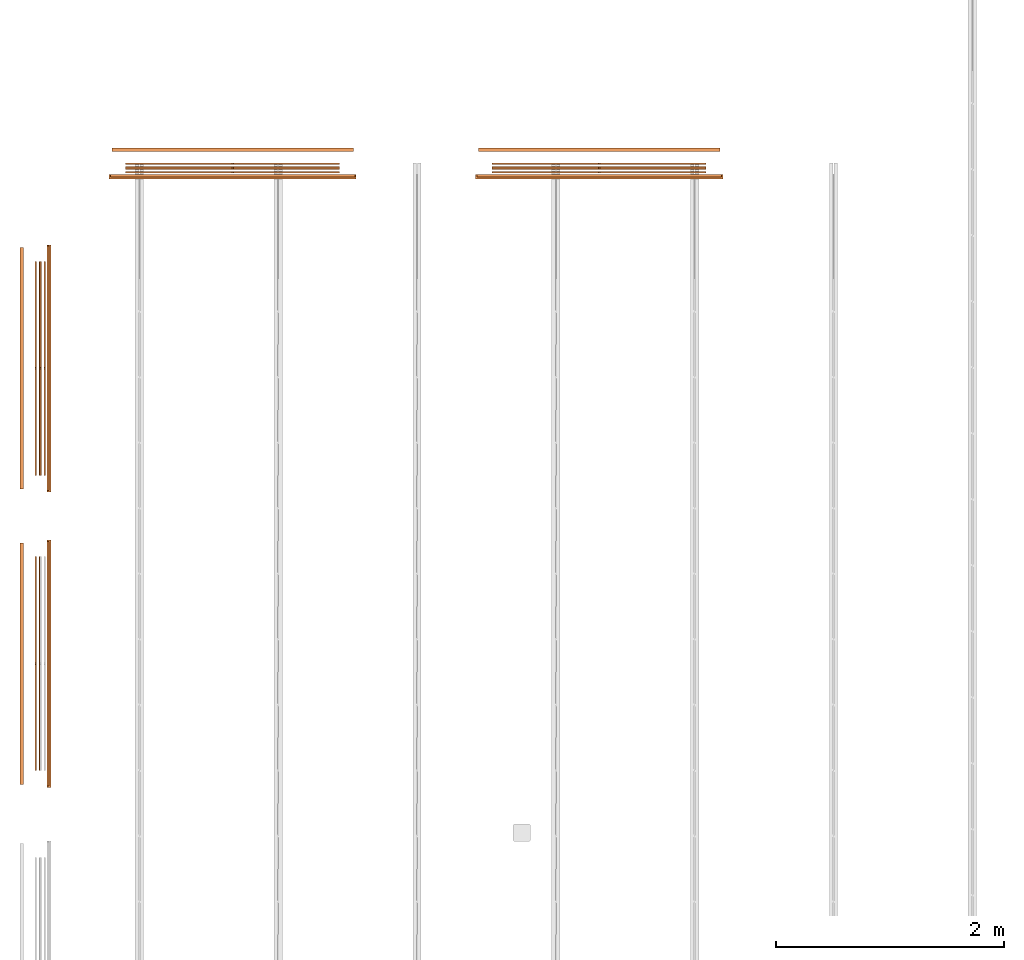
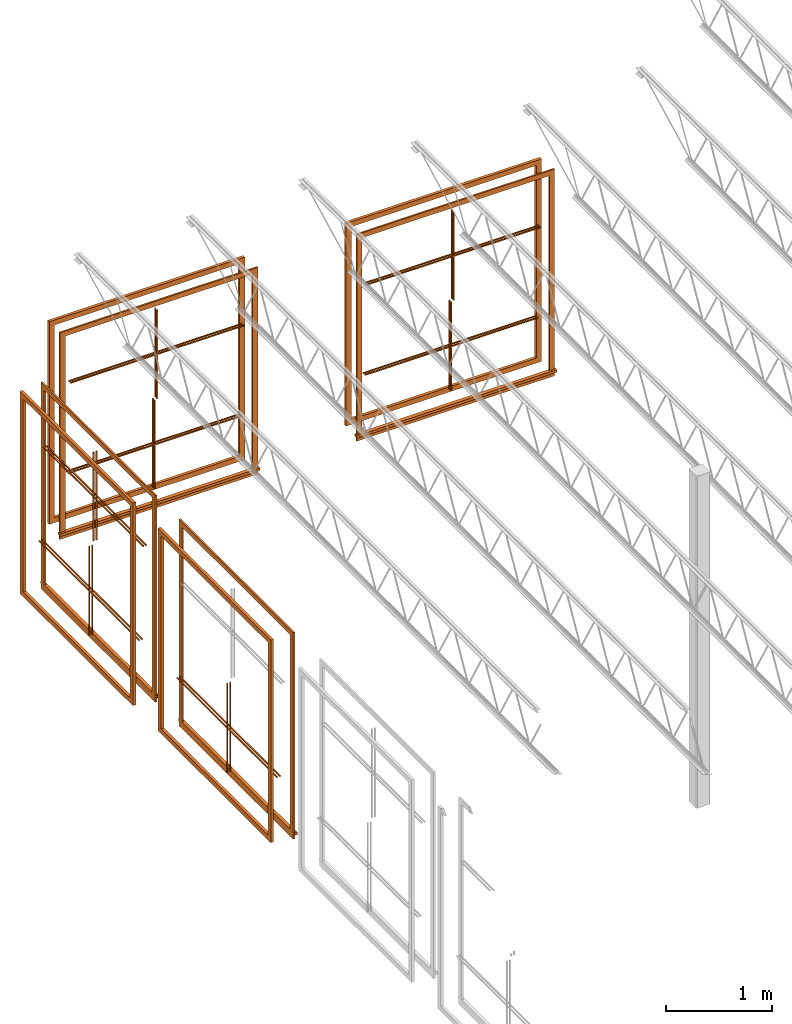
# One storey, part 30 of 31: 15 proxies.
"""IFC2X3 building model written with IfcOpenShell, lengths in feet."""

from ifc_helpers import new_model, entity, si_unit, converted_unit, derived_unit, direction, frame, frame_2d, origin, origin_2d_with_axis, place, context, subcontext, project, spatial, polyline, rectangle, outline, extrude, source, transform, mapped, material, material_list, type_object, type_shapes, element, save


model = new_model("IFC2X3")

# Units and contexts
model_context = context("Model", 3, precision=0.0001, world=origin(), true_north=direction((6.12303176911189e-17, 1.0)))
body_context = subcontext(model_context, "Body", "Model", "MODEL_VIEW")
ifc_project = project(units=[converted_unit("LENGTHUNIT", "FOOT", entity("IfcRatioMeasure", 0.3048), si_unit("LENGTHUNIT", "METRE"), dimensions=[1, 0, 0, 0, 0, 0, 0]), converted_unit("AREAUNIT", "SQUARE FOOT", entity("IfcRatioMeasure", 0.09290304), si_unit("AREAUNIT", "SQUARE_METRE"), dimensions=[2, 0, 0, 0, 0, 0, 0]), converted_unit("VOLUMEUNIT", "CUBIC FOOT", entity("IfcRatioMeasure", 0.028316846592), si_unit("VOLUMEUNIT", "CUBIC_METRE"), dimensions=[3, 0, 0, 0, 0, 0, 0]), converted_unit("PLANEANGLEUNIT", "DEGREE", entity("IfcRatioMeasure", 0.0174532925199433), si_unit("PLANEANGLEUNIT", "RADIAN"), dimensions=[0, 0, 0, 0, 0, 0, 0]), si_unit("MASSUNIT", "GRAM", prefix="KILO"), derived_unit("MASSDENSITYUNIT", [(si_unit("MASSUNIT", "GRAM", prefix="KILO"), 1), (si_unit("LENGTHUNIT", "METRE"), -3)]), si_unit("TIMEUNIT", "SECOND"), si_unit("FREQUENCYUNIT", "HERTZ"), si_unit("THERMODYNAMICTEMPERATUREUNIT", "DEGREE_CELSIUS"), derived_unit("THERMALTRANSMITTANCEUNIT", [(si_unit("MASSUNIT", "GRAM", prefix="KILO"), 1), (si_unit("THERMODYNAMICTEMPERATUREUNIT", "KELVIN"), -1), (si_unit("TIMEUNIT", "SECOND"), -3)]), derived_unit("VOLUMETRICFLOWRATEUNIT", [(si_unit("LENGTHUNIT", "METRE"), 3), (si_unit("TIMEUNIT", "SECOND"), -1)]), si_unit("ELECTRICCURRENTUNIT", "AMPERE"), si_unit("ELECTRICVOLTAGEUNIT", "VOLT"), si_unit("POWERUNIT", "WATT"), si_unit("FORCEUNIT", "NEWTON"), si_unit("ILLUMINANCEUNIT", "LUX"), si_unit("LUMINOUSFLUXUNIT", "LUMEN"), si_unit("LUMINOUSINTENSITYUNIT", "CANDELA"), derived_unit("USERDEFINED", [(si_unit("MASSUNIT", "GRAM", prefix="KILO"), -1), (si_unit("LENGTHUNIT", "METRE"), -2), (si_unit("TIMEUNIT", "SECOND"), 3), (si_unit("LUMINOUSFLUXUNIT", "LUMEN"), 1)]), derived_unit("LINEARVELOCITYUNIT", [(si_unit("LENGTHUNIT", "METRE"), 1), (si_unit("TIMEUNIT", "SECOND"), -1)]), si_unit("PRESSUREUNIT", "PASCAL"), derived_unit("USERDEFINED", [(si_unit("LENGTHUNIT", "METRE"), -2), (si_unit("MASSUNIT", "GRAM", prefix="KILO"), 1), (si_unit("TIMEUNIT", "SECOND"), -2)])], contexts=[model_context])

# Site, building, storey
site_placement = place(None, origin())
site = spatial("IfcSite", under=ifc_project, at=site_placement, CompositionType="ELEMENT")
building_placement = place(site_placement, origin())
building = spatial("IfcBuilding", under=site, at=building_placement, CompositionType="ELEMENT")
storey_placement = place(building_placement, frame((0.0, 0.0, 13.3333333333323)))
storey = spatial("IfcBuildingStorey", under=building, at=storey_placement, Name="Level 2", CompositionType="ELEMENT", Elevation=13.3333333333323)

# Proxies
ifc_material_1 = material(Name="Wood - Stained")
ifc_material_2 = material(Name="Clad - White 61141")
ifc_material_list_1 = material_list([ifc_material_1, ifc_material_2])
ifc_material_list_2 = material_list([ifc_material_1, ifc_material_2])
building_element_proxy_type_1 = type_object("IfcBuildingElementProxyType", Name="Muntin Pattern_2x2:Muntin Pattern_2x2", PredefinedType="NOTDEFINED", material=ifc_material_list_2)
shared_shape_1 = source(origin(), body_context, "Body", "SweptSolid", [
    extrude(outline(polyline([(-1.67187499999989, 0.0208333333334103), (-1.67187499999989, -0.0208333333332504), (-0.0208333333333748, -0.0208333333332504), (-0.0208333333333748, -3.08333333333347), (0.0208333333332895, -3.08333333333347), (0.0208333333332895, -0.0208333333332753), (1.67187500000003, -0.0208333333332753), (1.67187500000003, 0.0208333333333961), (0.0208333333333002, 0.0208333333333961), (0.0208333333333002, 3.08333333333319), (-0.0208333333333677, 3.08333333333319), (-0.0208333333333677, 0.0208333333334103), (-1.67187499999989, 0.0208333333334103)])), frame((-23.0360007308272, 53.8099399580353, 21.7447916666666), z_axis=(0.0, -1.0, 0.0), x_axis=(0.0, 0.0, -1.0)), (0.0, 0.0, -1.0), 0.0416666666666572),
    extrude(outline(polyline([(-1.6718749999996, 0.020833333333421), (-1.6718749999996, -0.0208333333332398), (-0.0208333333334672, -0.0208333333332398), (-0.0208333333334672, -3.08333333333347), (0.02083333333319, -3.08333333333347), (0.02083333333319, -0.0208333333332682), (1.67187500000009, -0.0208333333332682), (1.67187500000009, 0.0208333333333854), (0.0208333333332114, 0.0208333333333854), (0.0208333333332114, 3.08333333333318), (-0.0208333333334529, 3.08333333333318), (-0.0208333333334529, 0.020833333333421), (-1.6718749999996, 0.020833333333421)])), frame((-23.0360007308272, 53.7057732913685, 21.7447916666663), z_axis=(0.0, -1.0, 0.0), x_axis=(0.0, 0.0, -1.0)), (0.0, 0.0, -1.0), 0.0416666666666501),
])
type_shapes(building_element_proxy_type_1, [shared_shape_1])
proxy_1_placement = place(building_placement, origin())
element("IfcBuildingElementProxy", 1, at=proxy_1_placement, inside=storey, type_object=building_element_proxy_type_1, material=ifc_material_list_1, ObjectType="Muntin Pattern_2x2 : Muntin Pattern_2x2:Muntin Pattern_2x2", context=body_context, shape_type="MappedRepresentation", body=[
    mapped(shared_shape_1, transform((0.0, 0.0, 0.0), scale=1.0)),
])
ifc_material_list_3 = material_list([ifc_material_1, ifc_material_2])
ifc_material_list_4 = material_list([ifc_material_1, ifc_material_2])
building_element_proxy_type_2 = type_object("IfcBuildingElementProxyType", Name="Muntin Pattern_2x2:Muntin Pattern_2x2", PredefinedType="NOTDEFINED", material=ifc_material_list_4)
shared_shape_2 = source(origin(), body_context, "Body", "SweptSolid", [
    extrude(outline(polyline([(-1.67187499999989, 0.0208333333334103), (-1.67187499999989, -0.0208333333332504), (-0.0208333333333748, -0.0208333333332504), (-0.0208333333333748, -3.08333333333347), (0.0208333333332895, -3.08333333333347), (0.0208333333332895, -0.0208333333332753), (1.67187500000003, -0.0208333333332753), (1.67187500000003, 0.0208333333333961), (0.0208333333333002, 0.0208333333333961), (0.0208333333333002, 3.08333333333319), (-0.0208333333333677, 3.08333333333319), (-0.0208333333333677, 0.0208333333334103), (-1.67187499999989, 0.0208333333334103)])), frame((-23.0360007308272, 53.9557732913686, 18.2552083333333), z_axis=(0.0, -1.0, 0.0), x_axis=(0.0, 0.0, -1.0)), (0.0, 0.0, -1.0), 0.0416666666666572),
    extrude(outline(polyline([(-1.6718749999996, 0.020833333333421), (-1.6718749999996, -0.0208333333332398), (-0.0208333333334672, -0.0208333333332398), (-0.0208333333334672, -3.08333333333347), (0.02083333333319, -3.08333333333347), (0.02083333333319, -0.0208333333332682), (1.67187500000009, -0.0208333333332682), (1.67187500000009, 0.0208333333333854), (0.0208333333332149, 0.0208333333333854), (0.0208333333332149, 3.08333333333318), (-0.0208333333334458, 3.08333333333318), (-0.0208333333334458, 0.020833333333421), (-1.6718749999996, 0.020833333333421)])), frame((-23.0360007308272, 53.8516066247019, 18.2552083333331), z_axis=(0.0, -1.0, 0.0), x_axis=(0.0, 0.0, -1.0)), (0.0, 0.0, -1.0), 0.0416666666666501),
])
type_shapes(building_element_proxy_type_2, [shared_shape_2])
proxy_2_placement = place(building_placement, origin())
element("IfcBuildingElementProxy", 2, at=proxy_2_placement, inside=storey, type_object=building_element_proxy_type_2, material=ifc_material_list_3, ObjectType="Muntin Pattern_2x2 : Muntin Pattern_2x2:Muntin Pattern_2x2", context=body_context, shape_type="MappedRepresentation", body=[
    mapped(shared_shape_2, transform((0.0, 0.0, 0.0), scale=1.0)),
])
building_element_proxy_type_3 = type_object("IfcBuildingElementProxyType", Name="Trim-Window-Exterior-Flat:with Sill", PredefinedType="NOTDEFINED", material=ifc_material_2)
shared_shape_3 = source(origin(), body_context, "Body", "SweptSolid", [
    extrude(outline(polyline([(-3.71354166666666, -3.52083333333333), (3.80729166666667, -3.52083333333333), (3.80729166666667, 3.52083333333333), (-3.71354166666666, 3.52083333333333), (-3.71354166666666, 3.33333333333334), (3.61979166666666, 3.33333333333334), (3.61979166666666, -3.33333333333333), (-3.71354166666666, -3.33333333333333), (-3.71354166666666, -3.52083333333333)])), frame((-23.0360007308273, 53.6016066247019, 20.046875), z_axis=(0.0, 1.0, 0.0), x_axis=(0.0, 0.0, 1.0)), (0.0, 0.0, 1.0), 0.0625),
    extrude(outline(polyline([(-0.052459314639318, 0.0), (-0.052459314639318, -0.0624999999999361), (0.0436428358983285, -0.0624999999999361), (0.051707352027357, 0.0), (0.051707352027357, 0.0624999999999432), (-0.0210694553372051, 0.0624999999999432), (-0.0210694553372051, 0.0), (-0.052459314639318, 0.0)])), frame((-26.5985007308273, 53.6016066247019, 16.2816259813059), z_axis=(-1.0, 0.0, 0.0), x_axis=(0.0, 0.0, 1.0)), (0.0, 0.0, -1.0), 7.12500000000001),
    extrude(rectangle(XDim=0.0625, YDim=7.04166666666666, at=origin_2d_with_axis()), frame((-23.0360007308273, 53.6328566247019, 16.0730565259687), z_axis=(0.0, 0.0, 1.0), x_axis=(0.0, 1.0, 0.0)), (0.0, 0.0, 1.0), 0.187500000000004),
])
type_shapes(building_element_proxy_type_3, [shared_shape_3])
proxy_3_placement = place(building_placement, origin())
element("IfcBuildingElementProxy", 3, at=proxy_3_placement, inside=storey, type_object=building_element_proxy_type_3, material=ifc_material_2, ObjectType="with Sill : Trim-Window-Exterior-Flat:with Sill", context=body_context, shape_type="MappedRepresentation", body=[
    mapped(shared_shape_3, transform((0.0, 0.0, 0.0), scale=1.0)),
])
building_element_proxy_type_4 = type_object("IfcBuildingElementProxyType", Name="Trim-Window-Interior-Flat:Picture Frame", PredefinedType="NOTDEFINED", material=ifc_material_1)
shared_shape_4 = source(origin(), body_context, "Body", "SweptSolid", [
    extrude(outline(polyline([(-3.81249999999998, -3.47916666666666), (3.81249999999998, -3.47916666666666), (3.81249999999998, 3.47916666666666), (-3.81249999999998, 3.47916666666666), (-3.81249999999998, -3.47916666666666)]), holes=[polyline([(3.62499999999997, 3.29166666666668), (3.62499999999997, -3.29166666666666), (-3.62499999999998, -3.29166666666666), (-3.62499999999998, 3.29166666666668), (3.62499999999997, 3.29166666666668)])]), frame((-23.0360007308273, 54.3307732913686, 20.0), z_axis=(0.0, 1.0, 0.0), x_axis=(0.0, 0.0, -1.0)), (0.0, 0.0, 1.0), 0.104166666666664),
])
type_shapes(building_element_proxy_type_4, [shared_shape_4])
proxy_4_placement = place(building_placement, origin())
element("IfcBuildingElementProxy", 4, at=proxy_4_placement, inside=storey, type_object=building_element_proxy_type_4, material=ifc_material_1, ObjectType="Picture Frame : Trim-Window-Interior-Flat:Picture Frame", context=body_context, shape_type="MappedRepresentation", body=[
    mapped(shared_shape_4, transform((0.0, 0.0, 0.0), scale=1.0)),
])
ifc_material_list_5 = material_list([ifc_material_1, ifc_material_2])
ifc_material_list_6 = material_list([ifc_material_1, ifc_material_2])
building_element_proxy_type_5 = type_object("IfcBuildingElementProxyType", Name="Muntin Pattern_2x2:Muntin Pattern_2x2", PredefinedType="NOTDEFINED", material=ifc_material_list_6)
shared_shape_5 = source(origin(), body_context, "Body", "SweptSolid", [
    extrude(outline(polyline([(-1.67187499999989, 0.0208333333334068), (-1.67187499999989, -0.0208333333332575), (-0.0208333333333748, -0.0208333333332575), (-0.0208333333333748, -3.08333333333348), (0.0208333333332895, -3.08333333333348), (0.0208333333332895, -0.020833333333286), (1.67187500000003, -0.020833333333286), (1.67187500000003, 0.0208333333333854), (0.0208333333333002, 0.0208333333333854), (0.0208333333333002, 3.08333333333318), (-0.0208333333333677, 3.08333333333318), (-0.0208333333333677, 0.0208333333334068), (-1.67187499999989, 0.0208333333334068)])), frame((-33.5985007308272, 53.8099399580353, 21.7447916666666), z_axis=(0.0, -1.0, 0.0), x_axis=(0.0, 0.0, -1.0)), (0.0, 0.0, -1.0), 0.0416666666666572),
    extrude(outline(polyline([(-1.6718749999996, 0.0208333333334068), (-1.6718749999996, -0.0208333333332504), (-0.0208333333334672, -0.0208333333332504), (-0.0208333333334672, -3.08333333333349), (0.02083333333319, -3.08333333333349), (0.02083333333319, -0.0208333333332789), (1.67187500000009, -0.0208333333332789), (1.67187500000009, 0.0208333333333712), (0.0208333333332114, 0.0208333333333712), (0.0208333333332114, 3.08333333333316), (-0.0208333333334529, 3.08333333333316), (-0.0208333333334529, 0.0208333333334068), (-1.6718749999996, 0.0208333333334068)])), frame((-33.5985007308272, 53.7057732913686, 21.7447916666663), z_axis=(0.0, -1.0, 0.0), x_axis=(0.0, 0.0, -1.0)), (0.0, 0.0, -1.0), 0.0416666666666501),
])
type_shapes(building_element_proxy_type_5, [shared_shape_5])
proxy_5_placement = place(building_placement, origin())
element("IfcBuildingElementProxy", 5, at=proxy_5_placement, inside=storey, type_object=building_element_proxy_type_5, material=ifc_material_list_5, ObjectType="Muntin Pattern_2x2 : Muntin Pattern_2x2:Muntin Pattern_2x2", context=body_context, shape_type="MappedRepresentation", body=[
    mapped(shared_shape_5, transform((0.0, 0.0, 0.0), scale=1.0)),
])
ifc_material_list_7 = material_list([ifc_material_1, ifc_material_2])
ifc_material_list_8 = material_list([ifc_material_1, ifc_material_2])
building_element_proxy_type_6 = type_object("IfcBuildingElementProxyType", Name="Muntin Pattern_2x2:Muntin Pattern_2x2", PredefinedType="NOTDEFINED", material=ifc_material_list_8)
shared_shape_6 = source(origin(), body_context, "Body", "SweptSolid", [
    extrude(outline(polyline([(-1.67187499999989, 0.0208333333334068), (-1.67187499999989, -0.0208333333332575), (-0.0208333333333748, -0.0208333333332575), (-0.0208333333333748, -3.08333333333348), (0.0208333333332895, -3.08333333333348), (0.0208333333332895, -0.020833333333286), (1.67187500000003, -0.020833333333286), (1.67187500000003, 0.0208333333333854), (0.0208333333333002, 0.0208333333333854), (0.0208333333333002, 3.08333333333318), (-0.0208333333333677, 3.08333333333318), (-0.0208333333333677, 0.0208333333334068), (-1.67187499999989, 0.0208333333334068)])), frame((-33.5985007308272, 53.9557732913686, 18.2552083333333), z_axis=(0.0, -1.0, 0.0), x_axis=(0.0, 0.0, -1.0)), (0.0, 0.0, -1.0), 0.0416666666666572),
    extrude(outline(polyline([(-1.6718749999996, 0.0208333333334068), (-1.6718749999996, -0.0208333333332504), (-0.0208333333334672, -0.0208333333332504), (-0.0208333333334672, -3.08333333333349), (0.02083333333319, -3.08333333333349), (0.02083333333319, -0.0208333333332789), (1.67187500000009, -0.0208333333332789), (1.67187500000009, 0.0208333333333712), (0.0208333333332149, 0.0208333333333712), (0.0208333333332149, 3.08333333333316), (-0.0208333333334458, 3.08333333333316), (-0.0208333333334458, 0.0208333333334068), (-1.6718749999996, 0.0208333333334068)])), frame((-33.5985007308272, 53.8516066247019, 18.2552083333331), z_axis=(0.0, -1.0, 0.0), x_axis=(0.0, 0.0, -1.0)), (0.0, 0.0, -1.0), 0.0416666666666501),
])
type_shapes(building_element_proxy_type_6, [shared_shape_6])
proxy_6_placement = place(building_placement, origin())
element("IfcBuildingElementProxy", 6, at=proxy_6_placement, inside=storey, type_object=building_element_proxy_type_6, material=ifc_material_list_7, ObjectType="Muntin Pattern_2x2 : Muntin Pattern_2x2:Muntin Pattern_2x2", context=body_context, shape_type="MappedRepresentation", body=[
    mapped(shared_shape_6, transform((0.0, 0.0, 0.0), scale=1.0)),
])
building_element_proxy_type_7 = type_object("IfcBuildingElementProxyType", Name="Trim-Window-Exterior-Flat:with Sill", PredefinedType="NOTDEFINED", material=ifc_material_2)
shared_shape_7 = source(origin(), body_context, "Body", "SweptSolid", [
    extrude(outline(polyline([(-3.71354166666666, -3.52083333333334), (3.80729166666667, -3.52083333333334), (3.80729166666667, 3.52083333333332), (-3.71354166666666, 3.52083333333332), (-3.71354166666666, 3.33333333333333), (3.61979166666666, 3.33333333333333), (3.61979166666666, -3.33333333333333), (-3.71354166666666, -3.33333333333333), (-3.71354166666666, -3.52083333333334)])), frame((-33.5985007308273, 53.6016066247019, 20.046875), z_axis=(0.0, 1.0, 0.0), x_axis=(0.0, 0.0, 1.0)), (0.0, 0.0, 1.0), 0.0625),
    extrude(outline(polyline([(-0.052459314639318, 0.0), (-0.052459314639318, -0.0624999999999503), (0.0436428358983285, -0.0624999999999503), (0.051707352027357, 0.0), (0.051707352027357, 0.0624999999999289), (-0.0210694553372051, 0.0624999999999289), (-0.0210694553372051, 0.0), (-0.052459314639318, 0.0)])), frame((-37.1610007308273, 53.601606624702, 16.2816259813059), z_axis=(-1.0, 0.0, 0.0), x_axis=(0.0, 0.0, 1.0)), (0.0, 0.0, -1.0), 7.12500000000001),
    extrude(rectangle(XDim=0.0625, YDim=7.04166666666665, at=frame_2d((0.0, 1.77635683940025e-15), x_axis=(1.0, 0.0))), frame((-33.5985007308273, 53.6328566247019, 16.0730565259687), z_axis=(0.0, 0.0, 1.0), x_axis=(0.0, 1.0, 0.0)), (0.0, 0.0, 1.0), 0.187500000000004),
])
type_shapes(building_element_proxy_type_7, [shared_shape_7])
proxy_7_placement = place(building_placement, origin())
element("IfcBuildingElementProxy", 7, at=proxy_7_placement, inside=storey, type_object=building_element_proxy_type_7, material=ifc_material_2, ObjectType="with Sill : Trim-Window-Exterior-Flat:with Sill", context=body_context, shape_type="MappedRepresentation", body=[
    mapped(shared_shape_7, transform((0.0, 0.0, 0.0), scale=1.0)),
])
building_element_proxy_type_8 = type_object("IfcBuildingElementProxyType", Name="Trim-Window-Interior-Flat:Picture Frame", PredefinedType="NOTDEFINED", material=ifc_material_1)
shared_shape_8 = source(origin(), body_context, "Body", "SweptSolid", [
    extrude(outline(polyline([(-3.81249999999998, -3.47916666666665), (3.81249999999998, -3.47916666666665), (3.81249999999998, 3.47916666666666), (-3.81249999999998, 3.47916666666666), (-3.81249999999998, -3.47916666666665)]), holes=[polyline([(3.62499999999997, 3.29166666666667), (3.62499999999997, -3.29166666666665), (-3.62499999999998, -3.29166666666665), (-3.62499999999998, 3.29166666666667), (3.62499999999997, 3.29166666666667)])]), frame((-33.5985007308273, 54.3307732913686, 20.0), z_axis=(0.0, 1.0, 0.0), x_axis=(0.0, 0.0, -1.0)), (0.0, 0.0, 1.0), 0.104166666666664),
])
type_shapes(building_element_proxy_type_8, [shared_shape_8])
proxy_8_placement = place(building_placement, origin())
element("IfcBuildingElementProxy", 8, at=proxy_8_placement, inside=storey, type_object=building_element_proxy_type_8, material=ifc_material_1, ObjectType="Picture Frame : Trim-Window-Interior-Flat:Picture Frame", context=body_context, shape_type="MappedRepresentation", body=[
    mapped(shared_shape_8, transform((0.0, 0.0, 0.0), scale=1.0)),
])
ifc_material_list_9 = material_list([ifc_material_1, ifc_material_2])
ifc_material_list_10 = material_list([ifc_material_1, ifc_material_2])
building_element_proxy_type_9 = type_object("IfcBuildingElementProxyType", Name="Muntin Pattern_2x2:Muntin Pattern_2x2", PredefinedType="NOTDEFINED", material=ifc_material_list_10)
shared_shape_9 = source(origin(), body_context, "Body", "SweptSolid", [
    extrude(outline(polyline([(-0.020833333333421, -1.67187499999988), (0.0208333333332433, -1.67187499999988), (0.0208333333332433, -0.0208333333333712), (3.08333333333346, -0.0208333333333712), (3.08333333333346, 0.0208333333332931), (0.0208333333332718, 0.0208333333332931), (0.0208333333332718, 1.67187500000004), (-0.0208333333333997, 1.67187500000004), (-0.0208333333333997, 0.0208333333333037), (-3.08333333333319, 0.0208333333333037), (-3.08333333333319, -0.0208333333333641), (-0.020833333333421, -0.0208333333333641), (-0.020833333333421, -1.67187499999988)])), frame((-39.140167397494, 48.0807732913687, 21.7447916666666), z_axis=(1.0, 0.0, 0.0), x_axis=(0.0, -1.0, 0.0)), (0.0, 0.0, 1.0), 0.0416666666666572),
    extrude(outline(polyline([(-0.020833333333421, -1.6718749999996), (0.0208333333332362, -1.6718749999996), (0.0208333333332362, -0.0208333333334636), (3.08333333333348, -0.0208333333334636), (3.08333333333348, 0.0208333333331936), (0.0208333333332646, 0.0208333333331936), (0.0208333333332646, 1.67187500000009), (-0.0208333333333854, 1.67187500000009), (-0.0208333333333854, 0.0208333333332149), (-3.08333333333318, 0.0208333333332149), (-3.08333333333318, -0.0208333333334494), (-0.020833333333421, -0.0208333333334494), (-0.020833333333421, -1.6718749999996)])), frame((-39.0360007308273, 48.0807732913687, 21.7447916666663), z_axis=(1.0, 0.0, 0.0), x_axis=(0.0, -1.0, 0.0)), (0.0, 0.0, 1.0), 0.0416666666666501),
])
type_shapes(building_element_proxy_type_9, [shared_shape_9])
proxy_9_placement = place(building_placement, origin())
element("IfcBuildingElementProxy", 9, at=proxy_9_placement, inside=storey, type_object=building_element_proxy_type_9, material=ifc_material_list_9, ObjectType="Muntin Pattern_2x2 : Muntin Pattern_2x2:Muntin Pattern_2x2", context=body_context, shape_type="MappedRepresentation", body=[
    mapped(shared_shape_9, transform((0.0, 0.0, 0.0), scale=1.0)),
])
ifc_material_list_11 = material_list([ifc_material_1, ifc_material_2])
ifc_material_list_12 = material_list([ifc_material_1, ifc_material_2])
building_element_proxy_type_10 = type_object("IfcBuildingElementProxyType", Name="Muntin Pattern_2x2:Muntin Pattern_2x2", PredefinedType="NOTDEFINED", material=ifc_material_list_12)
shared_shape_10 = source(origin(), body_context, "Body", "SweptSolid", [
    extrude(outline(polyline([(-0.020833333333421, -1.67187499999989), (0.0208333333332433, -1.67187499999989), (0.0208333333332433, -0.0208333333333748), (3.08333333333346, -0.0208333333333748), (3.08333333333346, 0.0208333333332895), (0.0208333333332718, 0.0208333333332895), (0.0208333333332718, 1.67187500000003), (-0.0208333333333997, 1.67187500000003), (-0.0208333333333997, 0.0208333333333002), (-3.08333333333319, 0.0208333333333002), (-3.08333333333319, -0.0208333333333677), (-0.020833333333421, -0.0208333333333677), (-0.020833333333421, -1.67187499999989)])), frame((-39.2860007308274, 48.0807732913687, 18.2552083333333), z_axis=(1.0, 0.0, 0.0), x_axis=(0.0, -1.0, 0.0)), (0.0, 0.0, 1.0), 0.0416666666666572),
    extrude(outline(polyline([(-0.020833333333421, -1.6718749999996), (0.0208333333332362, -1.6718749999996), (0.0208333333332362, -0.0208333333334672), (3.08333333333348, -0.0208333333334672), (3.08333333333348, 0.02083333333319), (0.0208333333332646, 0.02083333333319), (0.0208333333332646, 1.67187500000009), (-0.0208333333333854, 1.67187500000009), (-0.0208333333333854, 0.0208333333332149), (-3.08333333333318, 0.0208333333332149), (-3.08333333333318, -0.0208333333334458), (-0.020833333333421, -0.0208333333334458), (-0.020833333333421, -1.6718749999996)])), frame((-39.1818340641606, 48.0807732913687, 18.2552083333331), z_axis=(1.0, 0.0, 0.0), x_axis=(0.0, -1.0, 0.0)), (0.0, 0.0, 1.0), 0.0416666666666501),
])
type_shapes(building_element_proxy_type_10, [shared_shape_10])
proxy_10_placement = place(building_placement, origin())
element("IfcBuildingElementProxy", 10, at=proxy_10_placement, inside=storey, type_object=building_element_proxy_type_10, material=ifc_material_list_11, ObjectType="Muntin Pattern_2x2 : Muntin Pattern_2x2:Muntin Pattern_2x2", context=body_context, shape_type="MappedRepresentation", body=[
    mapped(shared_shape_10, transform((0.0, 0.0, 0.0), scale=1.0)),
])
building_element_proxy_type_11 = type_object("IfcBuildingElementProxyType", Name="Trim-Window-Exterior-Flat:with Sill", PredefinedType="NOTDEFINED", material=ifc_material_2)
shared_shape_11 = source(origin(), body_context, "Body", "SweptSolid", [
    extrude(outline(polyline([(-3.52083333333333, -3.71354166666667), (-3.33333333333333, -3.71354166666667), (-3.33333333333333, 3.61979166666666), (3.33333333333334, 3.61979166666666), (3.33333333333334, -3.71354166666667), (3.52083333333332, -3.71354166666667), (3.52083333333332, 3.80729166666666), (-3.52083333333333, 3.80729166666666), (-3.52083333333333, -3.71354166666667)])), frame((-38.952667397494, 48.0807732913685, 20.046875), z_axis=(1.0, 0.0, 0.0), x_axis=(0.0, 1.0, 0.0)), (0.0, 0.0, 1.0), 0.0625),
    extrude(outline(polyline([(-0.052459314639318, 0.0), (-0.052459314639318, -0.0624999999999503), (0.0436428358983285, -0.0624999999999503), (0.051707352027357, 0.0), (0.051707352027357, 0.0624999999999289), (-0.0210694553372051, 0.0624999999999289), (-0.0210694553372051, 0.0), (-0.052459314639318, 0.0)])), frame((-38.8901673974941, 44.5182732913685, 16.2816259813059), z_axis=(0.0, -1.0, 0.0), x_axis=(0.0, 0.0, 1.0)), (0.0, 0.0, -1.0), 7.12500000000001),
    extrude(rectangle(XDim=0.0625, YDim=7.04166666666666, at=origin_2d_with_axis()), frame((-38.921417397494, 48.0807732913685, 16.0730565259687), z_axis=(0.0, 0.0, 1.0), x_axis=(-1.0, 0.0, 0.0)), (0.0, 0.0, 1.0), 0.187500000000004),
])
type_shapes(building_element_proxy_type_11, [shared_shape_11])
proxy_11_placement = place(building_placement, origin())
element("IfcBuildingElementProxy", 11, at=proxy_11_placement, inside=storey, type_object=building_element_proxy_type_11, material=ifc_material_2, ObjectType="with Sill : Trim-Window-Exterior-Flat:with Sill", context=body_context, shape_type="MappedRepresentation", body=[
    mapped(shared_shape_11, transform((0.0, 0.0, 0.0), scale=1.0)),
])
building_element_proxy_type_12 = type_object("IfcBuildingElementProxyType", Name="Trim-Window-Interior-Flat:Picture Frame", PredefinedType="NOTDEFINED", material=ifc_material_1)
shared_shape_12 = source(origin(), body_context, "Body", "SweptSolid", [
    extrude(outline(polyline([(-3.47916666666666, -3.81249999999998), (3.47916666666666, -3.81249999999998), (3.47916666666666, 3.81249999999998), (-3.47916666666666, 3.81249999999998), (-3.47916666666666, -3.81249999999998)]), holes=[polyline([(3.29166666666668, 3.62499999999997), (3.29166666666668, -3.62499999999998), (-3.29166666666666, -3.62499999999998), (-3.29166666666666, 3.62499999999997), (3.29166666666668, 3.62499999999997)])]), frame((-39.7235007308273, 48.0807732913685, 20.0), z_axis=(1.0, 0.0, 0.0), x_axis=(0.0, -1.0, 0.0)), (0.0, 0.0, 1.0), 0.104166666666664),
])
type_shapes(building_element_proxy_type_12, [shared_shape_12])
proxy_12_placement = place(building_placement, origin())
element("IfcBuildingElementProxy", 12, at=proxy_12_placement, inside=storey, type_object=building_element_proxy_type_12, material=ifc_material_1, ObjectType="Picture Frame : Trim-Window-Interior-Flat:Picture Frame", context=body_context, shape_type="MappedRepresentation", body=[
    mapped(shared_shape_12, transform((0.0, 0.0, 0.0), scale=1.0)),
])
ifc_material_list_13 = material_list([ifc_material_1, ifc_material_2])
ifc_material_list_14 = material_list([ifc_material_1, ifc_material_2])
building_element_proxy_type_13 = type_object("IfcBuildingElementProxyType", Name="Muntin Pattern_2x2:Muntin Pattern_2x2", PredefinedType="NOTDEFINED", material=ifc_material_list_14)
shared_shape_13 = source(origin(), body_context, "Body", "SweptSolid", [
    extrude(outline(polyline([(-0.020833333333421, -1.67187499999989), (0.0208333333332433, -1.67187499999989), (0.0208333333332433, -0.0208333333333748), (3.08333333333346, -0.0208333333333748), (3.08333333333346, 0.0208333333332895), (0.0208333333332718, 0.0208333333332895), (0.0208333333332718, 1.67187500000003), (-0.0208333333333997, 1.67187500000003), (-0.0208333333333997, 0.0208333333333002), (-3.08333333333319, 0.0208333333333002), (-3.08333333333319, -0.0208333333333677), (-0.020833333333421, -0.0208333333333677), (-0.020833333333421, -1.67187499999989)])), frame((-39.2860007308274, 39.5755649580354, 18.2552083333333), z_axis=(1.0, 0.0, 0.0), x_axis=(0.0, -1.0, 0.0)), (0.0, 0.0, 1.0), 0.0416666666666572),
    extrude(outline(polyline([(-0.020833333333421, -1.6718749999996), (0.0208333333332362, -1.6718749999996), (0.0208333333332362, -0.0208333333334672), (3.08333333333348, -0.0208333333334672), (3.08333333333348, 0.02083333333319), (0.0208333333332646, 0.02083333333319), (0.0208333333332646, 1.67187500000009), (-0.0208333333333854, 1.67187500000009), (-0.0208333333333854, 0.0208333333332149), (-3.08333333333318, 0.0208333333332149), (-3.08333333333318, -0.0208333333334458), (-0.020833333333421, -0.0208333333334458), (-0.020833333333421, -1.6718749999996)])), frame((-39.1818340641607, 39.5755649580354, 18.2552083333331), z_axis=(1.0, 0.0, 0.0), x_axis=(0.0, -1.0, 0.0)), (0.0, 0.0, 1.0), 0.0416666666666501),
])
type_shapes(building_element_proxy_type_13, [shared_shape_13])
proxy_13_placement = place(building_placement, origin())
element("IfcBuildingElementProxy", 13, at=proxy_13_placement, inside=storey, type_object=building_element_proxy_type_13, material=ifc_material_list_13, ObjectType="Muntin Pattern_2x2 : Muntin Pattern_2x2:Muntin Pattern_2x2", context=body_context, shape_type="MappedRepresentation", body=[
    mapped(shared_shape_13, transform((0.0, 0.0, 0.0), scale=1.0)),
])
building_element_proxy_type_14 = type_object("IfcBuildingElementProxyType", Name="Trim-Window-Exterior-Flat:with Sill", PredefinedType="NOTDEFINED", material=ifc_material_2)
shared_shape_14 = source(origin(), body_context, "Body", "SweptSolid", [
    extrude(outline(polyline([(-3.52083333333334, -3.71354166666667), (-3.33333333333333, -3.71354166666667), (-3.33333333333333, 3.61979166666666), (3.33333333333334, 3.61979166666666), (3.33333333333334, -3.71354166666667), (3.52083333333332, -3.71354166666667), (3.52083333333332, 3.80729166666666), (-3.52083333333334, 3.80729166666666), (-3.52083333333334, -3.71354166666667)])), frame((-38.952667397494, 39.5755649580353, 20.046875), z_axis=(1.0, 0.0, 0.0), x_axis=(0.0, 1.0, 0.0)), (0.0, 0.0, 1.0), 0.0625),
    extrude(outline(polyline([(-0.052459314639318, 0.0), (-0.052459314639318, -0.0624999999999503), (0.0436428358983285, -0.0624999999999503), (0.051707352027357, 0.0), (0.051707352027357, 0.0624999999999289), (-0.0210694553372051, 0.0624999999999289), (-0.0210694553372051, 0.0), (-0.052459314639318, 0.0)])), frame((-38.8901673974941, 36.0130649580353, 16.2816259813059), z_axis=(0.0, -1.0, 0.0), x_axis=(0.0, 0.0, 1.0)), (0.0, 0.0, -1.0), 7.12500000000001),
    extrude(rectangle(XDim=0.0625, YDim=7.04166666666666, at=origin_2d_with_axis()), frame((-38.921417397494, 39.5755649580353, 16.0730565259687), z_axis=(0.0, 0.0, 1.0), x_axis=(-1.0, 0.0, 0.0)), (0.0, 0.0, 1.0), 0.187500000000004),
])
type_shapes(building_element_proxy_type_14, [shared_shape_14])
proxy_14_placement = place(building_placement, origin())
element("IfcBuildingElementProxy", 14, at=proxy_14_placement, inside=storey, type_object=building_element_proxy_type_14, material=ifc_material_2, ObjectType="with Sill : Trim-Window-Exterior-Flat:with Sill", context=body_context, shape_type="MappedRepresentation", body=[
    mapped(shared_shape_14, transform((0.0, 0.0, 0.0), scale=1.0)),
])
building_element_proxy_type_15 = type_object("IfcBuildingElementProxyType", Name="Trim-Window-Interior-Flat:Picture Frame", PredefinedType="NOTDEFINED", material=ifc_material_1)
shared_shape_15 = source(origin(), body_context, "Body", "SweptSolid", [
    extrude(outline(polyline([(-3.47916666666666, -3.81249999999998), (3.47916666666666, -3.81249999999998), (3.47916666666666, 3.81249999999998), (-3.47916666666666, 3.81249999999998), (-3.47916666666666, -3.81249999999998)]), holes=[polyline([(3.29166666666667, 3.62499999999997), (3.29166666666667, -3.62499999999998), (-3.29166666666666, -3.62499999999998), (-3.29166666666666, 3.62499999999997), (3.29166666666667, 3.62499999999997)])]), frame((-39.7235007308274, 39.5755649580353, 20.0), z_axis=(1.0, 0.0, 0.0), x_axis=(0.0, -1.0, 0.0)), (0.0, 0.0, 1.0), 0.104166666666664),
])
type_shapes(building_element_proxy_type_15, [shared_shape_15])
proxy_15_placement = place(building_placement, origin())
element("IfcBuildingElementProxy", 15, at=proxy_15_placement, inside=storey, type_object=building_element_proxy_type_15, material=ifc_material_1, ObjectType="Picture Frame : Trim-Window-Interior-Flat:Picture Frame", context=body_context, shape_type="MappedRepresentation", body=[
    mapped(shared_shape_15, transform((0.0, 0.0, 0.0), scale=1.0)),
])

save(model, "model.ifc")
